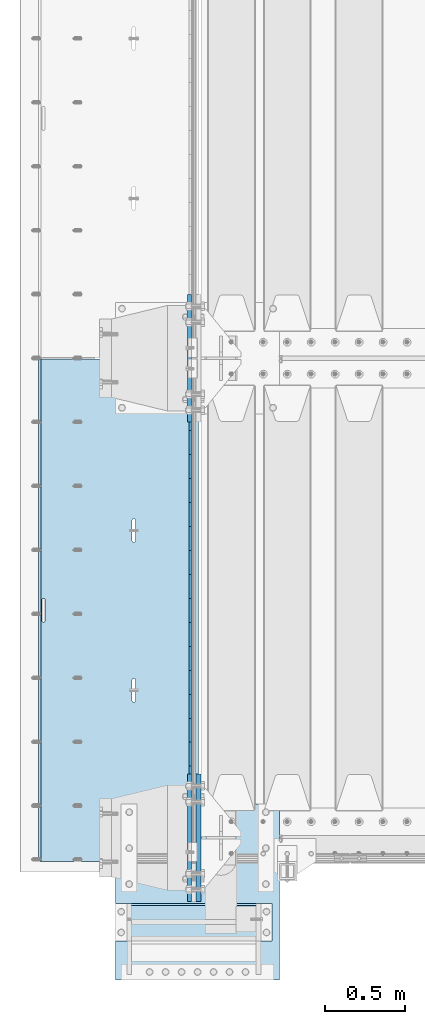
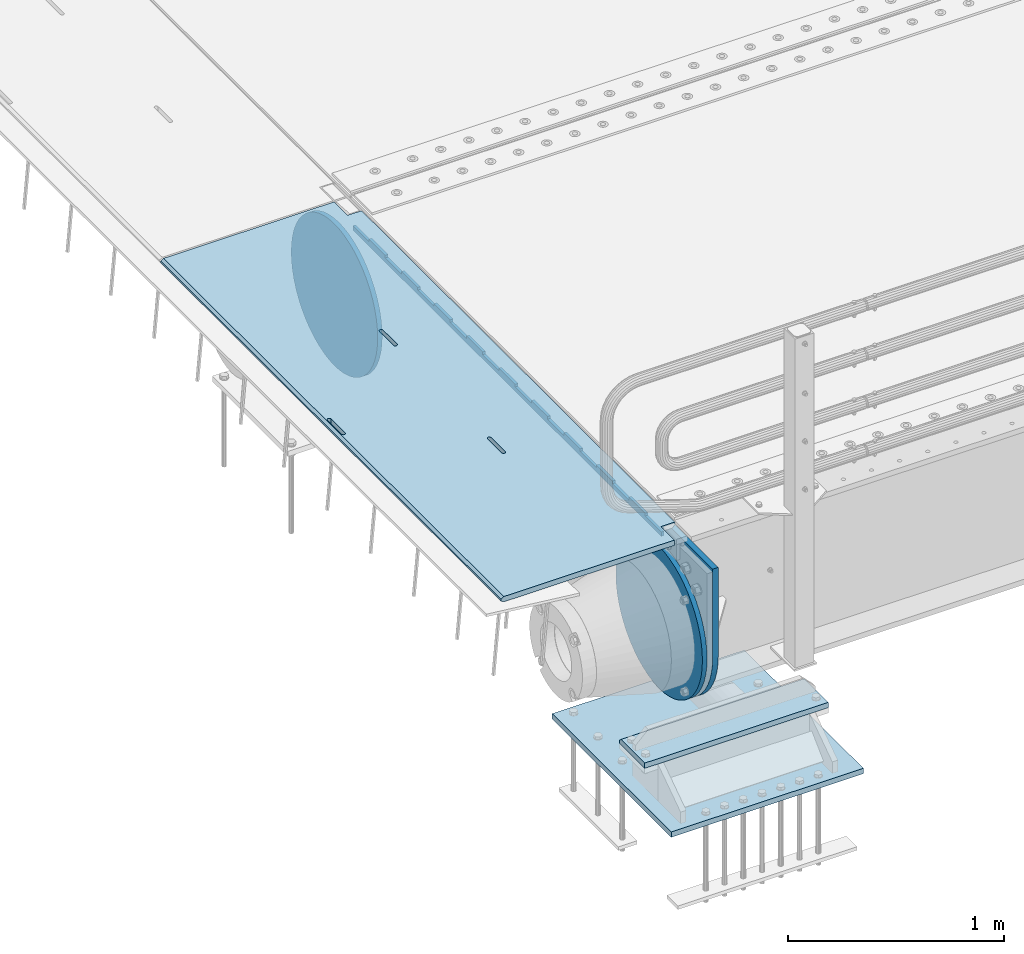
# One storey, part 195 of 257: 7 plates.
"""IFC2X3 building model written with IfcOpenShell, lengths in millimetres."""

from ifc_helpers import new_model, si_unit, frame, origin_with_axes, place, context, subcontext, project, spatial, faceted_brep, material, type_object, element, save


model = new_model("IFC2X3")

# Units and contexts
model_context = context("Model", 3, precision=1e-05, world=origin_with_axes())
body_context = subcontext(model_context, "Body", "Model", "MODEL_VIEW")
ifc_project = project(units=[si_unit("LENGTHUNIT", "METRE", prefix="MILLI"), si_unit("AREAUNIT", "SQUARE_METRE"), si_unit("VOLUMEUNIT", "CUBIC_METRE"), si_unit("MASSUNIT", "GRAM", prefix="KILO"), si_unit("TIMEUNIT", "SECOND"), si_unit("PLANEANGLEUNIT", "RADIAN"), si_unit("SOLIDANGLEUNIT", "STERADIAN"), si_unit("THERMODYNAMICTEMPERATUREUNIT", "DEGREE_CELSIUS"), si_unit("LUMINOUSINTENSITYUNIT", "LUMEN")], contexts=[model_context])

# Site, building, storey
site_placement = place(None, origin_with_axes())
site = spatial("IfcSite", under=ifc_project, at=site_placement, CompositionType="ELEMENT")
building_placement = place(site_placement, origin_with_axes())
building = spatial("IfcBuilding", under=site, at=building_placement, Name="Standard", CompositionType="ELEMENT")
storey_placement = place(building_placement, origin_with_axes())
storey = spatial("IfcBuildingStorey", under=building, at=storey_placement, Name="Undefined", CompositionType="ELEMENT", Elevation=0.0)

# Plates
ifc_material_1 = material(Name="STEEL/S355N")
plate_type_1 = type_object("IfcPlateType", PredefinedType="NOTDEFINED")
plate_1_placement = place(storey_placement, frame((42392.5, 2847.50009937252, -35.9858217339716), z_axis=(0.0, -0.999999999987744, -4.95099999993769e-06), x_axis=(0.0, 4.9510000093107e-06, -0.999999999987744)))
element("IfcPlate", 1, at=plate_1_placement, inside=storey, type_object=plate_type_1, material=ifc_material_1, context=body_context, shape_type="Brep", body=[
    faceted_brep([(7.105427357601e-15, -7.5, 0.0), (5.96145355302724e-12, -7.5, 150.0), (5.96145355302724e-12, 7.5, 150.0), (7.105427357601e-15, 7.5, 0.0), (-15.0000000000013, -7.5, 150.0), (-15.0000000000013, 7.5, 150.0), (-15.0000000000026, -7.5, 300.0), (-15.0000000000026, 7.5, 300.0), (1.00826014204358e-11, -7.5, 300.0), (1.00826014204358e-11, 7.5, 300.0), (1.05870867628255e-11, -7.5, 450.0), (1.05870867628255e-11, 7.5, 450.0), (-15.000000000004, -7.5, 450.0), (-15.000000000004, 7.5, 450.0), (-15.0000000000053, -7.5, 600.0), (-15.0000000000053, 7.5, 600.0), (1.65343294611375e-11, -7.5, 600.0), (1.65343294611375e-11, 7.5, 600.0), (1.88506987797155e-11, -7.5, 750.0), (1.88506987797155e-11, 7.5, 750.0), (-15.0000000000066, -7.5, 750.0), (-15.0000000000066, 7.5, 750.0), (-15.0000000000079, -7.5, 900.0), (-15.0000000000079, 7.5, 900.0), (2.48050469053851e-11, -7.5, 900.0), (2.48050469053851e-11, 7.5, 900.0), (2.7121416223963e-11, -7.5, 1050.0), (2.7121416223963e-11, 7.5, 1050.0), (-15.0000000000093, -7.5, 1050.0), (-15.0000000000093, 7.5, 1050.0), (-15.0000000000106, -7.5, 1200.0), (-15.0000000000106, 7.5, 1200.0), (3.12638803734444e-11, -7.5, 1200.0), (3.12638803734444e-11, 7.5, 1200.0), (3.53921336682106e-11, -7.5, 1350.0), (3.53921336682106e-11, 7.5, 1350.0), (-15.0000000000119, -7.5, 1350.0), (-15.0000000000119, 7.5, 1350.0), (-15.0000000000132, -7.5, 1500.0), (-15.0000000000132, 7.5, 1500.0), (3.77085029867885e-11, -7.5, 1500.0), (3.77085029867885e-11, 7.5, 1500.0), (4.36628511124582e-11, -7.5, 1650.0), (4.36628511124582e-11, 7.5, 1650.0), (-15.0000000000145, -7.5, 1650.0), (-15.0000000000145, 7.5, 1650.0), (-15.0000000000159, -7.5, 1800.0), (-15.0000000000159, 7.5, 1800.0), (4.41531256001326e-11, -7.5, 1800.0), (4.41531256001326e-11, 7.5, 1800.0), (4.82884843222564e-11, -7.5, 1950.0), (4.82884843222564e-11, 7.5, 1950.0), (-15.0000000000172, -7.5, 1950.0), (-15.0000000000172, 7.5, 1950.0), (-15.0000000000185, -7.5, 2100.0), (-15.0000000000185, 7.5, 2100.0), (5.24309484717378e-11, -7.5, 2100.0), (5.24309484717378e-11, 7.5, 2100.0), (5.47402123629581e-11, -7.5, 2250.0), (5.47402123629581e-11, 7.5, 2250.0), (-15.0000000000198, -7.5, 2250.0), (-15.0000000000198, 7.5, 2250.0), (-15.0000000000212, -7.5, 2400.0), (-15.0000000000212, 7.5, 2400.0), (6.06945604886278e-11, -7.5, 2400.0), (6.06945604886278e-11, 7.5, 2400.0), (6.30038243798481e-11, -7.5, 2550.0), (6.30038243798481e-11, 7.5, 2550.0), (-15.0000000000225, -7.5, 2550.0), (-15.0000000000225, 7.5, 2550.0), (-15.0000000000238, -7.5, 2700.0), (-15.0000000000238, 7.5, 2700.0), (6.53272991257836e-11, -7.5, 2700.0), (6.53272991257836e-11, 7.5, 2700.0), (7.12745418240957e-11, -7.5, 2850.0), (7.12745418240957e-11, 7.5, 2850.0), (24.9999999999749, -7.5, 2850.0), (24.9999999999749, 7.5, 2850.0), (25.0, -7.5, 0.0), (25.0, 7.5, 0.0)], [[[0, 1, 2, 3]], [[1, 4, 5, 2]], [[4, 6, 7, 5]], [[6, 8, 9, 7]], [[8, 10, 11, 9]], [[10, 12, 13, 11]], [[12, 14, 15, 13]], [[14, 16, 17, 15]], [[16, 18, 19, 17]], [[18, 20, 21, 19]], [[20, 22, 23, 21]], [[22, 24, 25, 23]], [[24, 26, 27, 25]], [[26, 28, 29, 27]], [[28, 30, 31, 29]], [[30, 32, 33, 31]], [[32, 34, 35, 33]], [[34, 36, 37, 35]], [[36, 38, 39, 37]], [[38, 40, 41, 39]], [[40, 42, 43, 41]], [[42, 44, 45, 43]], [[44, 46, 47, 45]], [[46, 48, 49, 47]], [[48, 50, 51, 49]], [[50, 52, 53, 51]], [[52, 54, 55, 53]], [[54, 56, 57, 55]], [[56, 58, 59, 57]], [[58, 60, 61, 59]], [[60, 62, 63, 61]], [[62, 64, 65, 63]], [[64, 66, 67, 65]], [[66, 68, 69, 67]], [[68, 70, 71, 69]], [[70, 72, 73, 71]], [[72, 74, 75, 73]], [[74, 76, 77, 75]], [[76, 78, 79, 77]], [[78, 0, 3, 79]], [[5, 7, 9, 11, 13, 15, 17, 19, 21, 23, 25, 27, 29, 31, 33, 35, 37, 39, 41, 43, 45, 47, 49, 51, 53, 55, 57, 59, 61, 63, 65, 67, 69, 71, 73, 75, 77, 79, 3, 2]], [[78, 76, 74, 72, 70, 68, 66, 64, 62, 60, 58, 56, 54, 52, 50, 48, 46, 44, 42, 40, 38, 36, 34, 32, 30, 28, 26, 24, 22, 20, 18, 16, 14, 12, 10, 8, 6, 4, 1, 0]]]),
])
plate_type_2 = type_object("IfcPlateType", PredefinedType="NOTDEFINED")
plate_2_placement = place(storey_placement, frame((42444.9962454292, 2994.99992612931, -0.984447299701587), z_axis=(0.0, -0.999999999987744, -4.95099999993769e-06), x_axis=(-0.999999999879068, -1.00000022173607e-09, -1.55519999981193e-05)))
element("IfcPlate", 2, at=plate_2_placement, inside=storey, type_object=plate_type_2, material=ifc_material_1, context=body_context, shape_type="Brep", body=[
    faceted_brep([(14.9998601691696, 15.0, 125.00002482085), (-0.000294611330900807, -0.000806902962787737, 124.999936248651), (-0.00191941577213584, 0.000806844426837205, 3020.00000492305), (14.9966216875109, 15.0, 3020.00007976653), (999.996459960938, 5.0, 1.81898940354586e-12), (984.996459960938, 15.0, 1.81898940354586e-12), (984.996459718779, 15.0, 3145.0), (999.996459718779, 5.0, 3145.0), (984.996459961367, -15.0, 1.81898940354586e-12), (999.996459960938, -4.99999999999848, 1.81898940354586e-12), (999.996459718779, -4.99999999999848, 3145.0), (984.996459719208, -15.0, 3145.0), (74.9997820615899, -15.0, 4.54747350886464e-13), (74.9996421866963, -15.0000000127077, 124.99993008412), (75.0001087166893, 15.0, 125.00007975412), (75.0002485915829, 15.0, 0.0), (-0.000449375191237777, -14.9999999951864, 124.999861417765), (395.48605660427, -15.0000000067239, 2004.40983005397), (395.48605660427, 15.0, 2004.40983005397), (394.996621766979, 15.0, 2007.49999999772), (394.996621766986, -15.0000000067363, 2007.49999999772), (396.906451823685, -15.0000000066914, 2001.6221474748), (396.906451823692, 15.0, 2001.6221474748), (399.118769244691, -15.0000000066418, 1999.40983005397), (399.118769244691, 15.0, 1999.40983005397), (401.906451823968, -15.0000000065801, 1997.98943483477), (401.906451823968, 15.0, 1997.98943483477), (404.996621767765, -15.0000000065123, 1997.49999999772), (404.996621767757, 15.0, 1997.49999999772), (408.086791711357, -15.0000000064451, 1997.98943483477), (408.086791711357, 15.0, 1997.98943483477), (410.874474290416, -15.0000000063849, 1999.40983005397), (410.874474290409, 15.0, 1999.40983005397), (413.086791711066, -15.0000000063378, 2001.62214747479), (413.086791711066, 15.0, 2001.62214747479), (414.507186930059, -15.0000000063082, 2004.40983005396), (414.507186930059, 15.0, 2004.40983005396), (414.99662176687, -15.0000000062992, 2007.49999999771), (414.99662176687, 15.0, 2007.49999999771), (414.996621756974, -15.0000000063698, 2137.49999999771), (414.996621756974, 15.0, 2137.49999999771), (414.507186919691, -15.0000000063821, 2140.59016994146), (414.507186919684, 15.0, 2140.59016994146), (413.086791700262, -15.0000000064147, 2143.37785252064), (413.086791700269, 15.0, 2143.37785252064), (410.87447427927, -15.0000000064642, 2145.59016994147), (410.87447427927, 15.0, 2145.59016994147), (408.086791699992, -15.0000000065259, 2147.01056516067), (408.086791699992, 15.0, 2147.01056516067), (404.996621756196, -15.0000000065937, 2147.49999999772), (404.996621756196, 15.0, 2147.49999999772), (401.906451812494, -15.000000006661, 2147.01056516067), (401.906451812487, 15.0, 2147.01056516067), (399.118769233435, -15.0000000067211, 2145.59016994147), (399.118769233435, 15.0, 2145.59016994147), (396.906451812771, -15.0000000067683, 2143.37785252064), (396.906451812771, 15.0, 2143.37785252064), (395.486056593792, -15.0000000067978, 2140.59016994147), (395.486056593792, 15.0, 2140.59016994147), (394.996621756982, -15.0000000068068, 2137.49999999772), (394.996621756982, 15.0, 2137.49999999772), (960.486056642767, -14.9999999941054, 1504.4098300542), (960.486056642767, 15.0, 1504.4098300542), (959.996621805483, 15.0, 1507.49999999795), (959.996621805483, -14.9999999941178, 1507.49999999795), (961.906451862189, -14.9999999940728, 1501.62214747503), (961.906451862189, 15.0, 1501.62214747503), (964.118769283188, -14.9999999940233, 1499.4098300542), (964.118769283188, 15.0, 1499.4098300542), (966.906451862465, -14.9999999939616, 1497.989434835), (966.906451862473, 15.0, 1497.989434835), (969.996621806255, -14.9999999938938, 1497.49999999795), (969.996621806247, 15.0, 1497.49999999795), (973.086791749854, -14.9999999938266, 1497.989434835), (973.086791749854, 15.0, 1497.989434835), (975.874474328921, -14.9999999937664, 1499.4098300542), (975.874474328913, 15.0, 1499.4098300542), (978.086791749571, -14.9999999937193, 1501.62214747502), (978.086791749571, 15.0, 1501.62214747502), (979.507186968556, -14.9999999936897, 1504.4098300542), (979.507186968556, 15.0, 1504.4098300542), (979.996621805367, -14.9999999936807, 1507.49999999794), (979.996621805367, 15.0, 1507.49999999794), (979.996621795464, -14.9999999937513, 1637.49999999794), (979.996621795464, 15.0, 1637.49999999794), (979.507186958173, -14.9999999937636, 1640.59016994169), (979.507186958181, 15.0, 1640.59016994169), (978.086791738773, -14.9999999937962, 1643.37785252087), (978.086791738773, 15.0, 1643.37785252087), (975.874474317774, -14.9999999938457, 1645.5901699417), (975.874474317774, 15.0, 1645.5901699417), (973.086791738489, -14.9999999939074, 1647.0105651609), (973.086791738489, 15.0, 1647.0105651609), (969.996621794693, -14.9999999939752, 1647.49999999795), (969.9966217947, 15.0, 1647.49999999795), (966.906451850991, -14.9999999940425, 1647.0105651609), (966.906451850991, 15.0, 1647.0105651609), (964.118769271932, -14.9999999941026, 1645.5901699417), (964.118769271932, 15.0, 1645.5901699417), (961.906451851275, -14.9999999941498, 1643.37785252088), (961.906451851275, 15.0, 1643.37785252088), (960.486056632282, -14.9999999941793, 1640.5901699417), (960.486056632282, 15.0, 1640.5901699417), (959.996621795472, -14.9999999941883, 1637.49999999795), (959.996621795472, 15.0, 1637.49999999795), (74.9967306509934, 15.0, 3145.0), (74.9962640909871, -15.0, 3145.0), (74.9968705258798, 15.0, 3020.00007982413), (74.9964039658807, -15.0, 3019.99993015413), (-0.00046036208368605, -15.00000004538, 3019.99993008592), (395.486056670779, -15.0000000062551, 1140.59016994195), (396.906451889765, -15.0000000062256, 1143.37785252113), (399.118769310422, -15.0000000061784, 1145.59016994195), (401.906451889496, -15.0000000061183, 1147.01056516115), (404.996621833197, -15.000000006051, 1147.4999999982), (408.086791776987, -15.0000000059832, 1147.01056516115), (410.874474356264, -15.0000000059215, 1145.59016994195), (413.086791777263, -15.000000005872, 1143.37785252112), (414.507186996678, -15.0000000058394, 1140.59016994194), (414.996621833961, -15.0000000058271, 1137.49999999819), (414.996621843864, -15.0000000057565, 1007.49999999819), (414.507187007053, -15.0000000057655, 1004.40983005444), (413.086791788061, -15.0000000057951, 1001.62214747527), (410.874474367411, -15.0000000058422, 999.409830054449), (408.086791788344, -15.0000000059024, 997.989434835249), (404.996621844752, -15.0000000059696, 997.499999998201), (401.906451900963, -15.0000000060374, 997.989434835249), (399.118769321678, -15.0000000060991, 999.409830054451), (396.906451900679, -15.0000000061487, 1001.62214747528), (395.486056681264, -15.0000000061812, 1004.40983005445), (394.996621843988, -15.0000000061936, 1007.4999999982), (394.996621833969, -15.0000000062641, 1137.4999999982), (396.906451900679, 15.0, 1001.62214747528), (395.486056681264, 15.0, 1004.40983005445), (399.118769321678, 15.0, 999.409830054451), (401.906451900963, 15.0, 997.989434835249), (404.996621844744, 15.0, 997.499999998201), (408.086791788344, 15.0, 997.989434835249), (410.874474367403, 15.0, 999.409830054449), (413.086791788061, 15.0, 1001.62214747527), (414.507187007061, 15.0, 1004.40983005444), (414.996621843871, 15.0, 1007.49999999819), (414.996621833961, 15.0, 1137.49999999819), (414.507186996678, 15.0, 1140.59016994194), (413.086791777263, 15.0, 1143.37785252112), (410.874474356264, 15.0, 1145.59016994195), (408.086791776987, 15.0, 1147.01056516115), (404.996621833197, 15.0, 1147.4999999982), (401.906451889488, 15.0, 1147.01056516115), (399.118769310422, 15.0, 1145.59016994195), (396.906451889765, 15.0, 1143.37785252113), (395.486056670779, 15.0, 1140.59016994195), (394.996621833969, 15.0, 1137.4999999982), (394.99662184398, 15.0, 1007.4999999982)], [[[0, 1, 2, 3]], [[4, 5, 6, 7]], [[8, 9, 10, 11]], [[12, 13, 14, 15]], [[14, 13, 16, 1, 0]], [[17, 18, 19, 20]], [[21, 22, 18, 17]], [[23, 24, 22, 21]], [[25, 26, 24, 23]], [[27, 28, 26, 25]], [[29, 30, 28, 27]], [[31, 32, 30, 29]], [[33, 34, 32, 31]], [[35, 36, 34, 33]], [[37, 38, 36, 35]], [[39, 40, 38, 37]], [[41, 42, 40, 39]], [[43, 44, 42, 41]], [[45, 46, 44, 43]], [[47, 48, 46, 45]], [[49, 50, 48, 47]], [[51, 52, 50, 49]], [[53, 54, 52, 51]], [[55, 56, 54, 53]], [[57, 58, 56, 55]], [[59, 60, 58, 57]], [[20, 19, 60, 59]], [[61, 62, 63, 64]], [[65, 66, 62, 61]], [[67, 68, 66, 65]], [[69, 70, 68, 67]], [[71, 72, 70, 69]], [[73, 74, 72, 71]], [[75, 76, 74, 73]], [[77, 78, 76, 75]], [[79, 80, 78, 77]], [[81, 82, 80, 79]], [[83, 84, 82, 81]], [[85, 86, 84, 83]], [[87, 88, 86, 85]], [[89, 90, 88, 87]], [[91, 92, 90, 89]], [[93, 94, 92, 91]], [[95, 96, 94, 93]], [[97, 98, 96, 95]], [[99, 100, 98, 97]], [[101, 102, 100, 99]], [[103, 104, 102, 101]], [[64, 63, 104, 103]], [[9, 8, 12, 15, 5, 4]], [[10, 9, 4, 7]], [[105, 106, 11, 10, 7, 6]], [[106, 105, 107, 108]], [[109, 108, 107, 3, 2]], [[106, 108, 109, 16, 13, 12, 8, 11], [101, 99, 97, 95, 93, 91, 89, 87, 85, 83, 81, 79, 77, 75, 73, 71, 69, 67, 65, 61, 64, 103], [57, 55, 53, 51, 49, 47, 45, 43, 41, 39, 37, 35, 33, 31, 29, 27, 25, 23, 21, 17, 20, 59], [110, 111, 112, 113, 114, 115, 116, 117, 118, 119, 120, 121, 122, 123, 124, 125, 126, 127, 128, 129, 130, 131]], [[128, 132, 133, 129]], [[127, 134, 132, 128]], [[126, 135, 134, 127]], [[125, 136, 135, 126]], [[124, 137, 136, 125]], [[123, 138, 137, 124]], [[122, 139, 138, 123]], [[121, 140, 139, 122]], [[120, 141, 140, 121]], [[119, 142, 141, 120]], [[118, 143, 142, 119]], [[117, 144, 143, 118]], [[116, 145, 144, 117]], [[115, 146, 145, 116]], [[114, 147, 146, 115]], [[113, 148, 147, 114]], [[112, 149, 148, 113]], [[111, 150, 149, 112]], [[110, 151, 150, 111]], [[131, 152, 151, 110]], [[130, 153, 152, 131]], [[129, 133, 153, 130]], [[107, 105, 6, 5, 15, 14, 0, 3], [132, 134, 135, 136, 137, 138, 139, 140, 141, 142, 143, 144, 145, 146, 147, 148, 149, 150, 151, 152, 153, 133], [22, 24, 26, 28, 30, 32, 34, 36, 38, 40, 42, 44, 46, 48, 50, 52, 54, 56, 58, 60, 19, 18], [66, 68, 70, 72, 74, 76, 78, 80, 82, 84, 86, 88, 90, 92, 94, 96, 98, 100, 102, 104, 63, 62]], [[16, 109, 2, 1]]]),
])
plate_type_3 = type_object("IfcPlateType", PredefinedType="NOTDEFINED")
plate_3_placement = place(storey_placement, frame((42445.0, -400.0, -20.0), z_axis=(0.0, 1.0, 0.0), x_axis=(0.0, 0.0, -1.0)))
element("IfcPlate", 3, at=plate_3_placement, inside=storey, type_object=plate_type_3, material=ifc_material_1, context=body_context, shape_type="Brep", body=[
    faceted_brep([(855.0, -15.0, 572.96311467154), (855.0, 15.0, 572.96311467154), (849.182410261294, 15.0, 585.889268817531), (849.182410261294, -15.0, 585.889268817531), (824.193546357474, 15.0, 627.225898692485), (824.193546357474, -15.0, 627.225898692485), (794.404299268454, 15.0, 665.249063296341), (794.404299268454, -15.0, 665.249063296341), (760.249063296334, 15.0, 699.404299268464), (760.249063296334, -15.0, 699.404299268464), (722.22589869248, 15.0, 729.193546357486), (722.22589869248, -15.0, 729.193546357486), (680.889268817528, 15.0, 754.182410261309), (680.889268817528, -15.0, 754.182410261309), (636.841954817037, 15.0, 774.006497074193), (636.841954817037, -15.0, 774.006497074193), (590.726265715048, 15.0, 788.37672697045), (590.726265715048, -15.0, 788.37672697045), (543.214672102156, 15.0, 797.083549639254), (543.214672102156, -15.0, 797.083549639254), (495.0, -15.0, 800.000000000029), (495.0, 15.0, 800.0), (494.999999999412, -15.0, 0.0), (494.999999999412, 15.0, 0.0), (543.214672102129, 15.0, 2.91645036080718), (543.214672102129, -15.0, 2.91645036080718), (590.726265715023, 15.0, 11.6232730296088), (590.726265715023, -15.0, 11.6232730296088), (636.841954817014, 15.0, 25.9935029258631), (636.841954817014, -15.0, 25.9935029258631), (680.889268817507, 15.0, 45.8175897387455), (680.889268817507, -15.0, 45.8175897387455), (722.225898692462, 15.0, 70.8064536425663), (722.225898692462, -15.0, 70.8064536425663), (760.249063296318, 15.0, 100.595700731588), (760.249063296318, -15.0, 100.595700731588), (794.404299268441, 15.0, 134.750936703711), (794.404299268441, -15.0, 134.750936703711), (824.193546357463, 15.0, 172.774101307567), (824.193546357463, -15.0, 172.774101307567), (849.182410261284, 15.0, 214.110731182522), (849.182410261284, -15.0, 214.110731182522), (855.0, -15.0, 227.036885328535), (855.0, 15.0, 227.036885328535), (0.0, -15.0, 0.0), (0.0, 15.0, 0.0), (0.0, 15.0, 800.0), (0.0, -15.0, 800.0)], [[[0, 1, 2, 3]], [[3, 2, 4, 5]], [[5, 4, 6, 7]], [[7, 6, 8, 9]], [[9, 8, 10, 11]], [[11, 10, 12, 13]], [[13, 12, 14, 15]], [[15, 14, 16, 17]], [[17, 16, 18, 19]], [[20, 19, 18, 21]], [[22, 23, 24, 25]], [[25, 24, 26, 27]], [[27, 26, 28, 29]], [[29, 28, 30, 31]], [[31, 30, 32, 33]], [[33, 32, 34, 35]], [[35, 34, 36, 37]], [[37, 36, 38, 39]], [[39, 38, 40, 41]], [[42, 41, 40, 43]], [[42, 43, 1, 0]], [[44, 45, 23, 22]], [[16, 14, 12, 10, 8, 6, 4, 2, 1, 43, 40, 38, 36, 34, 32, 30, 28, 26, 24, 23, 45, 46, 21, 18]], [[44, 47, 46, 45]], [[46, 47, 20, 21]], [[47, 44, 22, 25, 27, 29, 31, 33, 35, 37, 39, 41, 42, 0, 3, 5, 7, 9, 11, 13, 15, 17, 19, 20]]]),
])
ifc_material_2 = material()
plate_type_4 = type_object("IfcPlateType", PredefinedType="NOTDEFINED")
plate_4_placement = place(storey_placement, frame((42905.0, -645.0, -803.000000000004), z_axis=(0.0, 1.0, 0.0), x_axis=(-1.0, 0.0, 0.0)))
element("IfcPlate", 4, at=plate_4_placement, inside=storey, type_object=plate_type_4, material=ifc_material_2, context=body_context, shape_type="Brep", body=[
    faceted_brep([(979.0, 0.0, 235.0), (979.0, 15.0, 220.0), (0.0, 15.0, 220.0), (0.0, 0.0, 235.0), (0.0, 15.0, 0.0), (0.0, -15.0, 0.0), (0.0, -15.0, 235.0), (979.0, -15.0, 235.0), (979.0, -15.0, 0.0), (979.0, 15.0, 0.0)], [[[0, 1, 2, 3]], [[4, 5, 6, 3, 2]], [[6, 7, 0, 3]], [[7, 8, 9, 1, 0]], [[8, 5, 4, 9]], [[9, 4, 2, 1]], [[8, 7, 6, 5]]]),
])
plate_type_5 = type_object("IfcPlateType", PredefinedType="NOTDEFINED")
plate_5_placement = place(storey_placement, frame((41926.0, -890.0, -1043.0), z_axis=(1.0, 0.0, 0.0), x_axis=(0.0, 1.0, 0.0)))
element("IfcPlate", 5, at=plate_5_placement, inside=storey, type_object=plate_type_5, material=ifc_material_2, context=body_context, shape_type="Brep", body=[
    faceted_brep([(0.0, -15.0, 0.0), (3.03448287013453e-05, -15.0, 1025.0), (3.03448287013453e-05, 15.0, 1025.0), (0.0, 15.0, 0.0), (1100.0, -15.0, 1025.0), (1100.0, 15.0, 1025.0), (1100.0, -15.0, -2.18278728425503e-11), (1100.0, 15.0, -2.18278728425503e-11)], [[[0, 1, 2, 3]], [[1, 4, 5, 2]], [[4, 6, 7, 5]], [[6, 0, 3, 7]], [[5, 7, 3, 2]], [[6, 4, 1, 0]]]),
])
plate_type_6 = type_object("IfcPlateType", PredefinedType="NOTDEFINED")
plate_6_placement = place(storey_placement, frame((42387.5, 400.0, -114.999999999998), z_axis=(0.0, 0.0, -1.0), x_axis=(0.0, -1.0, 0.0)))
element("IfcPlate", 6, at=plate_6_placement, inside=storey, type_object=plate_type_6, material=ifc_material_1, context=body_context, shape_type="Brep", body=[
    faceted_brep([(-1.13686837721616e-13, -12.5, 400.0), (2.91645036077841, -12.5, 448.214672102129), (2.91645036077841, 12.5, 448.214672102129), (-1.13686837721616e-13, 12.5, 400.0), (11.6232730295792, -12.5, 495.726265715023), (11.6232730295792, 12.5, 495.726265715023), (25.993502925834, -12.5, 541.841954817014), (25.993502925834, 12.5, 541.841954817014), (45.817589738716, -12.5, 585.889268817507), (45.817589738716, 12.5, 585.889268817507), (70.8064536425373, -12.5, 627.225898692462), (70.8064536425373, 12.5, 627.225898692462), (100.595700731559, -12.5, 665.249063296318), (100.595700731559, 12.5, 665.249063296318), (134.750936703682, -12.5, 699.40429926844), (134.750936703682, 12.5, 699.40429926844), (172.774101307538, -12.5, 729.193546357462), (172.774101307538, 12.5, 729.193546357462), (214.110731182492, -12.5, 754.182410261284), (214.110731182492, 12.5, 754.182410261284), (258.158045182986, -12.5, 774.006497074166), (258.158045182986, 12.5, 774.006497074166), (304.273734284977, -12.5, 788.376726970421), (304.273734284977, 12.5, 788.376726970421), (351.78532789787, -12.5, 797.083549639221), (351.78532789787, 12.5, 797.083549639221), (400.0, -12.5, 800.0), (400.0, 12.5, 800.0), (448.214672102129, -12.5, 797.083549639222), (448.214672102129, 12.5, 797.083549639222), (495.726265715023, -12.5, 788.376726970421), (495.726265715023, 12.5, 788.376726970421), (541.841954817014, -12.5, 774.006497074166), (541.841954817014, 12.5, 774.006497074166), (585.889268817507, -12.5, 754.182410261284), (585.889268817507, 12.5, 754.182410261284), (627.225898692462, -12.5, 729.193546357463), (627.225898692462, 12.5, 729.193546357463), (665.249063296318, -12.5, 699.404299268441), (665.249063296318, 12.5, 699.404299268441), (699.40429926844, -12.5, 665.249063296318), (699.40429926844, 12.5, 665.249063296318), (729.193546357463, -12.5, 627.225898692462), (729.193546357463, 12.5, 627.225898692462), (754.182410261284, -12.5, 585.889268817507), (754.182410261284, 12.5, 585.889268817507), (774.006497074166, -12.5, 541.841954817014), (774.006497074166, 12.5, 541.841954817014), (788.376726970421, -12.5, 495.726265715023), (788.376726970421, 12.5, 495.726265715023), (797.083549639222, -12.5, 448.214672102129), (797.083549639222, 12.5, 448.214672102129), (800.0, -12.5, 400.0), (800.0, 12.5, 400.0), (797.083549639222, -12.5, 351.785327897871), (797.083549639222, 12.5, 351.785327897871), (788.376726970421, -12.5, 304.273734284977), (788.376726970421, 12.5, 304.273734284977), (774.006497074166, -12.5, 258.158045182986), (774.006497074166, 12.5, 258.158045182986), (754.182410261284, -12.5, 214.110731182493), (754.182410261284, 12.5, 214.110731182493), (729.193546357463, -12.5, 172.774101307538), (729.193546357463, 12.5, 172.774101307538), (699.40429926844, -12.5, 134.750936703682), (699.40429926844, 12.5, 134.750936703682), (665.249063296318, -12.5, 100.59570073156), (665.249063296318, 12.5, 100.59570073156), (627.225898692462, -12.5, 70.8064536425375), (627.225898692462, 12.5, 70.8064536425375), (585.889268817507, -12.5, 45.817589738716), (585.889268817507, 12.5, 45.817589738716), (541.841954817014, -12.5, 25.9935029258342), (541.841954817014, 12.5, 25.9935029258342), (495.726265715023, -12.5, 11.6232730295793), (495.726265715023, 12.5, 11.6232730295793), (448.214672102129, -12.5, 2.91645036077847), (448.214672102129, 12.5, 2.91645036077847), (400.0, -12.5, -5.6843418860808e-14), (400.0, 12.5, -5.6843418860808e-14), (351.785327897871, -12.5, 2.91645036077836), (351.785327897871, 12.5, 2.91645036077836), (304.273734284977, -12.5, 11.6232730295792), (304.273734284977, 12.5, 11.6232730295792), (258.158045182986, -12.5, 25.993502925834), (258.158045182986, 12.5, 25.993502925834), (214.110731182492, -12.5, 45.817589738716), (214.110731182492, 12.5, 45.817589738716), (172.774101307538, -12.5, 70.8064536425374), (172.774101307538, 12.5, 70.8064536425374), (134.750936703682, -12.5, 100.595700731559), (134.750936703682, 12.5, 100.595700731559), (100.59570073156, -12.5, 134.750936703682), (100.59570073156, 12.5, 134.750936703682), (70.8064536425373, -12.5, 172.774101307538), (70.8064536425373, 12.5, 172.774101307538), (45.817589738716, -12.5, 214.110731182492), (45.817589738716, 12.5, 214.110731182492), (25.993502925834, -12.5, 258.158045182986), (25.993502925834, 12.5, 258.158045182986), (11.6232730295791, -12.5, 304.273734284977), (11.6232730295791, 12.5, 304.273734284977), (2.91645036077836, -12.5, 351.785327897871), (2.91645036077836, 12.5, 351.785327897871)], [[[0, 1, 2, 3]], [[1, 4, 5, 2]], [[4, 6, 7, 5]], [[6, 8, 9, 7]], [[8, 10, 11, 9]], [[10, 12, 13, 11]], [[12, 14, 15, 13]], [[14, 16, 17, 15]], [[16, 18, 19, 17]], [[18, 20, 21, 19]], [[20, 22, 23, 21]], [[22, 24, 25, 23]], [[24, 26, 27, 25]], [[26, 28, 29, 27]], [[28, 30, 31, 29]], [[30, 32, 33, 31]], [[32, 34, 35, 33]], [[34, 36, 37, 35]], [[36, 38, 39, 37]], [[38, 40, 41, 39]], [[40, 42, 43, 41]], [[42, 44, 45, 43]], [[44, 46, 47, 45]], [[46, 48, 49, 47]], [[48, 50, 51, 49]], [[50, 52, 53, 51]], [[52, 54, 55, 53]], [[54, 56, 57, 55]], [[56, 58, 59, 57]], [[58, 60, 61, 59]], [[60, 62, 63, 61]], [[62, 64, 65, 63]], [[64, 66, 67, 65]], [[66, 68, 69, 67]], [[68, 70, 71, 69]], [[70, 72, 73, 71]], [[72, 74, 75, 73]], [[74, 76, 77, 75]], [[76, 78, 79, 77]], [[78, 80, 81, 79]], [[80, 82, 83, 81]], [[82, 84, 85, 83]], [[84, 86, 87, 85]], [[86, 88, 89, 87]], [[88, 90, 91, 89]], [[90, 92, 93, 91]], [[92, 94, 95, 93]], [[94, 96, 97, 95]], [[96, 98, 99, 97]], [[98, 100, 101, 99]], [[100, 102, 103, 101]], [[102, 0, 3, 103]], [[5, 7, 9, 11, 13, 15, 17, 19, 21, 23, 25, 27, 29, 31, 33, 35, 37, 39, 41, 43, 45, 47, 49, 51, 53, 55, 57, 59, 61, 63, 65, 67, 69, 71, 73, 75, 77, 79, 81, 83, 85, 87, 89, 91, 93, 95, 97, 99, 101, 103, 3, 2]], [[102, 100, 98, 96, 94, 92, 90, 88, 86, 84, 82, 80, 78, 76, 74, 72, 70, 68, 66, 64, 62, 60, 58, 56, 54, 52, 50, 48, 46, 44, 42, 40, 38, 36, 34, 32, 30, 28, 26, 24, 22, 20, 18, 16, 14, 12, 10, 8, 6, 4, 1, 0]]]),
])
plate_7_placement = place(storey_placement, frame((42387.5, 3400.0, -114.999999999998), z_axis=(0.0, 0.0, -1.0), x_axis=(0.0, -1.0, 0.0)))
element("IfcPlate", 7, at=plate_7_placement, inside=storey, type_object=plate_type_6, material=ifc_material_1, context=body_context, shape_type="Brep", body=[
    faceted_brep([(-1.13686837721616e-13, -12.5, 400.0), (2.91645036077841, -12.5, 448.214672102129), (2.91645036077841, 12.5, 448.214672102129), (-1.13686837721616e-13, 12.5, 400.0), (11.6232730295792, -12.5, 495.726265715023), (11.6232730295792, 12.5, 495.726265715023), (25.993502925834, -12.5, 541.841954817014), (25.993502925834, 12.5, 541.841954817014), (45.817589738716, -12.5, 585.889268817507), (45.817589738716, 12.5, 585.889268817507), (70.8064536425373, -12.5, 627.225898692462), (70.8064536425373, 12.5, 627.225898692462), (100.595700731559, -12.5, 665.249063296318), (100.595700731559, 12.5, 665.249063296318), (134.750936703682, -12.5, 699.40429926844), (134.750936703682, 12.5, 699.40429926844), (172.774101307538, -12.5, 729.193546357462), (172.774101307538, 12.5, 729.193546357462), (214.110731182492, -12.5, 754.182410261284), (214.110731182492, 12.5, 754.182410261284), (258.158045182986, -12.5, 774.006497074166), (258.158045182986, 12.5, 774.006497074166), (304.273734284977, -12.5, 788.376726970421), (304.273734284977, 12.5, 788.376726970421), (351.78532789787, -12.5, 797.083549639221), (351.78532789787, 12.5, 797.083549639221), (400.0, -12.5, 800.0), (400.0, 12.5, 800.0), (448.214672102129, -12.5, 797.083549639222), (448.214672102129, 12.5, 797.083549639222), (495.726265715023, -12.5, 788.376726970421), (495.726265715023, 12.5, 788.376726970421), (541.841954817014, -12.5, 774.006497074166), (541.841954817014, 12.5, 774.006497074166), (585.889268817507, -12.5, 754.182410261284), (585.889268817507, 12.5, 754.182410261284), (627.225898692462, -12.5, 729.193546357463), (627.225898692462, 12.5, 729.193546357463), (665.249063296318, -12.5, 699.404299268441), (665.249063296318, 12.5, 699.404299268441), (699.40429926844, -12.5, 665.249063296318), (699.40429926844, 12.5, 665.249063296318), (729.193546357463, -12.5, 627.225898692462), (729.193546357463, 12.5, 627.225898692462), (754.182410261284, -12.5, 585.889268817507), (754.182410261284, 12.5, 585.889268817507), (774.006497074166, -12.5, 541.841954817014), (774.006497074166, 12.5, 541.841954817014), (788.376726970421, -12.5, 495.726265715023), (788.376726970421, 12.5, 495.726265715023), (797.083549639222, -12.5, 448.214672102129), (797.083549639222, 12.5, 448.214672102129), (800.0, -12.5, 400.0), (800.0, 12.5, 400.0), (797.083549639222, -12.5, 351.785327897871), (797.083549639222, 12.5, 351.785327897871), (788.376726970421, -12.5, 304.273734284977), (788.376726970421, 12.5, 304.273734284977), (774.006497074166, -12.5, 258.158045182986), (774.006497074166, 12.5, 258.158045182986), (754.182410261284, -12.5, 214.110731182493), (754.182410261284, 12.5, 214.110731182493), (729.193546357463, -12.5, 172.774101307538), (729.193546357463, 12.5, 172.774101307538), (699.40429926844, -12.5, 134.750936703682), (699.40429926844, 12.5, 134.750936703682), (665.249063296318, -12.5, 100.59570073156), (665.249063296318, 12.5, 100.59570073156), (627.225898692462, -12.5, 70.8064536425375), (627.225898692462, 12.5, 70.8064536425375), (585.889268817507, -12.5, 45.817589738716), (585.889268817507, 12.5, 45.817589738716), (541.841954817014, -12.5, 25.9935029258342), (541.841954817014, 12.5, 25.9935029258342), (495.726265715023, -12.5, 11.6232730295793), (495.726265715023, 12.5, 11.6232730295793), (448.214672102129, -12.5, 2.91645036077847), (448.214672102129, 12.5, 2.91645036077847), (400.0, -12.5, -5.6843418860808e-14), (400.0, 12.5, -5.6843418860808e-14), (351.785327897871, -12.5, 2.91645036077836), (351.785327897871, 12.5, 2.91645036077836), (304.273734284977, -12.5, 11.6232730295792), (304.273734284977, 12.5, 11.6232730295792), (258.158045182986, -12.5, 25.993502925834), (258.158045182986, 12.5, 25.993502925834), (214.110731182492, -12.5, 45.817589738716), (214.110731182492, 12.5, 45.817589738716), (172.774101307538, -12.5, 70.8064536425374), (172.774101307538, 12.5, 70.8064536425374), (134.750936703682, -12.5, 100.595700731559), (134.750936703682, 12.5, 100.595700731559), (100.59570073156, -12.5, 134.750936703682), (100.59570073156, 12.5, 134.750936703682), (70.8064536425373, -12.5, 172.774101307538), (70.8064536425373, 12.5, 172.774101307538), (45.817589738716, -12.5, 214.110731182492), (45.817589738716, 12.5, 214.110731182492), (25.993502925834, -12.5, 258.158045182986), (25.993502925834, 12.5, 258.158045182986), (11.6232730295791, -12.5, 304.273734284977), (11.6232730295791, 12.5, 304.273734284977), (2.91645036077836, -12.5, 351.785327897871), (2.91645036077836, 12.5, 351.785327897871)], [[[0, 1, 2, 3]], [[1, 4, 5, 2]], [[4, 6, 7, 5]], [[6, 8, 9, 7]], [[8, 10, 11, 9]], [[10, 12, 13, 11]], [[12, 14, 15, 13]], [[14, 16, 17, 15]], [[16, 18, 19, 17]], [[18, 20, 21, 19]], [[20, 22, 23, 21]], [[22, 24, 25, 23]], [[24, 26, 27, 25]], [[26, 28, 29, 27]], [[28, 30, 31, 29]], [[30, 32, 33, 31]], [[32, 34, 35, 33]], [[34, 36, 37, 35]], [[36, 38, 39, 37]], [[38, 40, 41, 39]], [[40, 42, 43, 41]], [[42, 44, 45, 43]], [[44, 46, 47, 45]], [[46, 48, 49, 47]], [[48, 50, 51, 49]], [[50, 52, 53, 51]], [[52, 54, 55, 53]], [[54, 56, 57, 55]], [[56, 58, 59, 57]], [[58, 60, 61, 59]], [[60, 62, 63, 61]], [[62, 64, 65, 63]], [[64, 66, 67, 65]], [[66, 68, 69, 67]], [[68, 70, 71, 69]], [[70, 72, 73, 71]], [[72, 74, 75, 73]], [[74, 76, 77, 75]], [[76, 78, 79, 77]], [[78, 80, 81, 79]], [[80, 82, 83, 81]], [[82, 84, 85, 83]], [[84, 86, 87, 85]], [[86, 88, 89, 87]], [[88, 90, 91, 89]], [[90, 92, 93, 91]], [[92, 94, 95, 93]], [[94, 96, 97, 95]], [[96, 98, 99, 97]], [[98, 100, 101, 99]], [[100, 102, 103, 101]], [[102, 0, 3, 103]], [[5, 7, 9, 11, 13, 15, 17, 19, 21, 23, 25, 27, 29, 31, 33, 35, 37, 39, 41, 43, 45, 47, 49, 51, 53, 55, 57, 59, 61, 63, 65, 67, 69, 71, 73, 75, 77, 79, 81, 83, 85, 87, 89, 91, 93, 95, 97, 99, 101, 103, 3, 2]], [[102, 100, 98, 96, 94, 92, 90, 88, 86, 84, 82, 80, 78, 76, 74, 72, 70, 68, 66, 64, 62, 60, 58, 56, 54, 52, 50, 48, 46, 44, 42, 40, 38, 36, 34, 32, 30, 28, 26, 24, 22, 20, 18, 16, 14, 12, 10, 8, 6, 4, 1, 0]]]),
])

save(model, "model.ifc")
